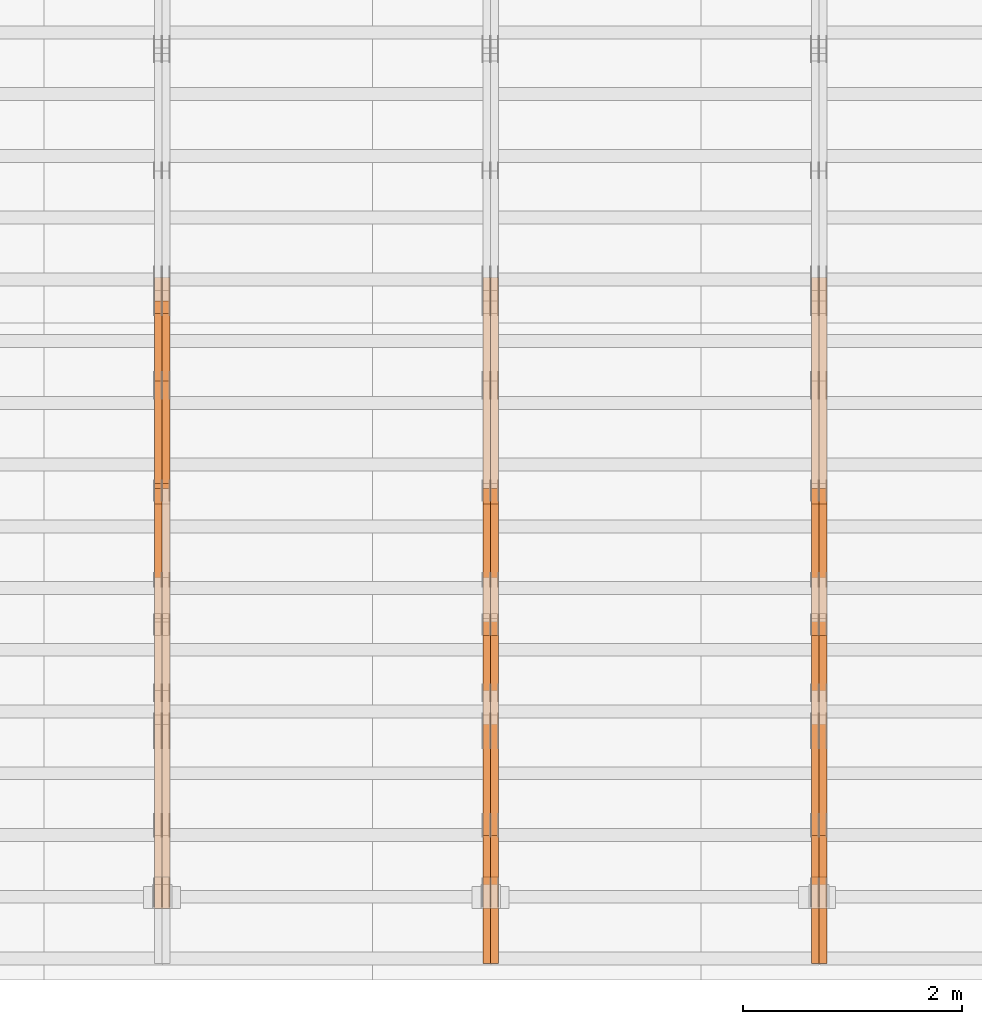
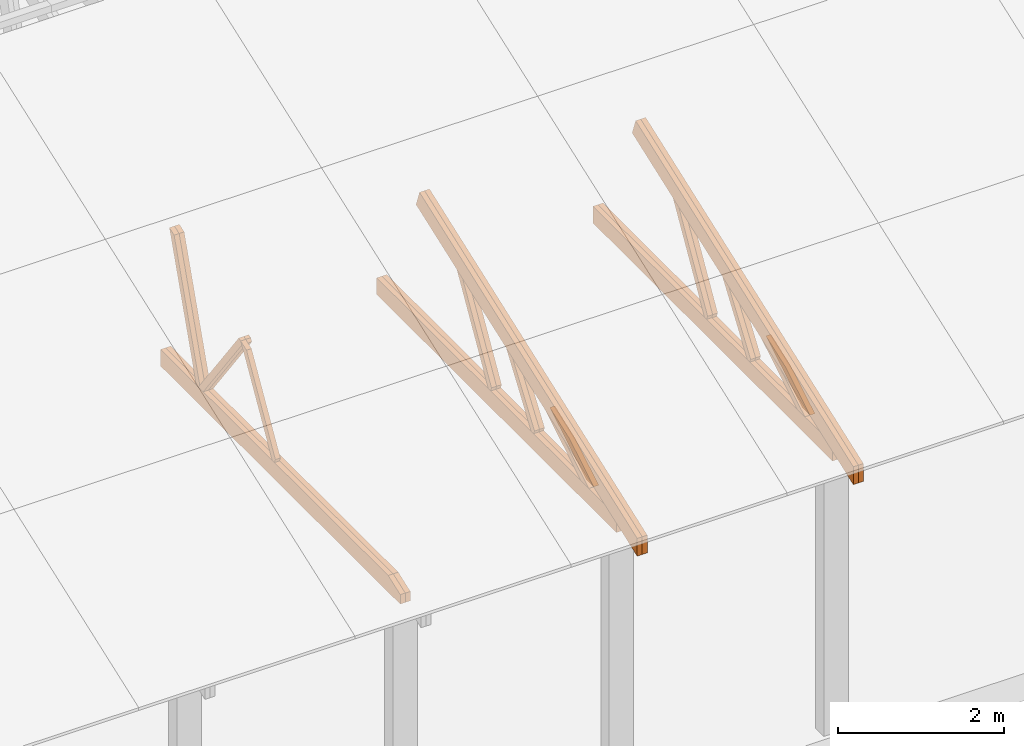
# One storey, part 23 of 189: 27 proxies.
"""IFC2X3 building model written with IfcOpenShell, lengths in millimetres."""

from ifc_helpers import new_model, entity, si_unit, converted_unit, derived_unit, direction, frame, origin, place, context, subcontext, project, spatial, polyline, outline, extrude, source, transform, mapped, material, type_object, type_shapes, element, save


model = new_model("IFC2X3")

# Units and contexts
model_context = context("Model", 3, precision=0.01, world=origin(), true_north=direction((6.12303176911189e-17, 1.0)))
body_context = subcontext(model_context, "Body", "Model", "MODEL_VIEW")
ifc_project = project(units=[si_unit("LENGTHUNIT", "METRE", prefix="MILLI"), si_unit("AREAUNIT", "SQUARE_METRE"), si_unit("VOLUMEUNIT", "CUBIC_METRE"), converted_unit("PLANEANGLEUNIT", "DEGREE", entity("IfcRatioMeasure", 0.0174532925199433), si_unit("PLANEANGLEUNIT", "RADIAN"), dimensions=[0, 0, 0, 0, 0, 0, 0]), si_unit("MASSUNIT", "GRAM", prefix="KILO"), derived_unit("MASSDENSITYUNIT", [(si_unit("MASSUNIT", "GRAM", prefix="KILO"), 1), (si_unit("LENGTHUNIT", "METRE"), -3)]), si_unit("TIMEUNIT", "SECOND"), si_unit("FREQUENCYUNIT", "HERTZ"), si_unit("THERMODYNAMICTEMPERATUREUNIT", "DEGREE_CELSIUS"), derived_unit("THERMALTRANSMITTANCEUNIT", [(si_unit("MASSUNIT", "GRAM", prefix="KILO"), 1), (si_unit("THERMODYNAMICTEMPERATUREUNIT", "KELVIN"), -1), (si_unit("TIMEUNIT", "SECOND"), -3)]), derived_unit("VOLUMETRICFLOWRATEUNIT", [(si_unit("LENGTHUNIT", "METRE"), 3), (si_unit("TIMEUNIT", "SECOND"), -1)]), si_unit("ELECTRICCURRENTUNIT", "AMPERE"), si_unit("ELECTRICVOLTAGEUNIT", "VOLT"), si_unit("POWERUNIT", "WATT"), si_unit("FORCEUNIT", "NEWTON"), si_unit("ILLUMINANCEUNIT", "LUX"), si_unit("LUMINOUSFLUXUNIT", "LUMEN"), si_unit("LUMINOUSINTENSITYUNIT", "CANDELA"), derived_unit("USERDEFINED", [(si_unit("MASSUNIT", "GRAM", prefix="KILO"), -1), (si_unit("LENGTHUNIT", "METRE"), -2), (si_unit("TIMEUNIT", "SECOND"), 3), (si_unit("LUMINOUSFLUXUNIT", "LUMEN"), 1)]), derived_unit("LINEARVELOCITYUNIT", [(si_unit("LENGTHUNIT", "METRE"), 1), (si_unit("TIMEUNIT", "SECOND"), -1)]), si_unit("PRESSUREUNIT", "PASCAL"), derived_unit("USERDEFINED", [(si_unit("LENGTHUNIT", "METRE"), -2), (si_unit("MASSUNIT", "GRAM", prefix="KILO"), 1), (si_unit("TIMEUNIT", "SECOND"), -2)])], contexts=[model_context])

# Site, building, storey
site_placement = place(None, origin())
site = spatial("IfcSite", under=ifc_project, at=site_placement, CompositionType="ELEMENT")
building_placement = place(site_placement, origin())
building = spatial("IfcBuilding", under=site, at=building_placement, CompositionType="ELEMENT")
storey_placement = place(building_placement, origin())
storey = spatial("IfcBuildingStorey", under=building, at=storey_placement, Name="Default", CompositionType="ELEMENT", Elevation=0.0)

# Proxies
ifc_material_1 = material(Name="IfcSurfaceStyle #160734")
building_element_proxy_type_1 = type_object("IfcBuildingElementProxyType", Name="T1-W11 160732", PredefinedType="NOTDEFINED", material=ifc_material_1)
shared_shape_1 = source(origin(), body_context, "Body", "SweptSolid", [
    extrude(outline(polyline([(593.358012843793, -552.565239103314), (742.388662259985, -552.565239103314), (-410.498749190676, 401.275038694583), (-462.246133468927, 382.44069706518), (-463.001792444175, 321.414742446865), (593.358012843793, -552.565239103314)])), frame((599.94412413079, 47.5003788877286, 0.0), z_axis=(0.0, 0.0, 1.0), x_axis=(0.770483455324544, 0.637459994879013, 0.0)), (0.0, 0.0, 1.0), 69.9999999999999),
])
type_shapes(building_element_proxy_type_1, [shared_shape_1])
proxy_1_placement = place(building_placement, frame((30300.0, 2983.26655629375, 269.034992751429), z_axis=(-1.0, 0.0, 0.0), x_axis=(0.0, 0.505995901100606, 0.862535882192379)))
element("IfcBuildingElementProxy", 1, at=proxy_1_placement, inside=storey, type_object=building_element_proxy_type_1, material=ifc_material_1, Name="T1-W11", context=body_context, shape_type="MappedRepresentation", body=[
    mapped(shared_shape_1, transform((0.0, 0.0, 0.0), scale=1.0)),
])
ifc_material_2 = material(Name="IfcSurfaceStyle #160668")
building_element_proxy_type_2 = type_object("IfcBuildingElementProxyType", Name="T1-W11 160666", PredefinedType="NOTDEFINED", material=ifc_material_2)
shared_shape_2 = source(origin(), body_context, "Body", "SweptSolid", [
    extrude(outline(polyline([(593.358012843793, -552.565239103314), (742.388662259985, -552.565239103314), (-410.498749190676, 401.275038694583), (-462.246133468927, 382.44069706518), (-463.001792444175, 321.414742446865), (593.358012843793, -552.565239103314)])), frame((599.94412413079, 47.5003788877286, 0.0), z_axis=(0.0, 0.0, 1.0), x_axis=(0.770483455324544, 0.637459994879013, 0.0)), (0.0, 0.0, 1.0), 69.9999999999999),
])
type_shapes(building_element_proxy_type_2, [shared_shape_2])
proxy_2_placement = place(building_placement, frame((30230.0, 2983.26655629375, 269.034992751429), z_axis=(-1.0, 0.0, 0.0), x_axis=(0.0, 0.505995901100606, 0.862535882192379)))
element("IfcBuildingElementProxy", 2, at=proxy_2_placement, inside=storey, type_object=building_element_proxy_type_2, material=ifc_material_2, Name="T1-W11", context=body_context, shape_type="MappedRepresentation", body=[
    mapped(shared_shape_2, transform((0.0, 0.0, 0.0), scale=1.0)),
])
ifc_material_3 = material(Name="IfcSurfaceStyle #160206")
building_element_proxy_type_3 = type_object("IfcBuildingElementProxyType", Name="T1-W13 160204", PredefinedType="NOTDEFINED", material=ifc_material_3)
shared_shape_3 = source(origin(), body_context, "Body", "SweptSolid", [
    extrude(outline(polyline([(404.740440720218, -341.48092914206), (570.336320797765, -341.48092914206), (-287.911826743206, 259.650691447848), (-342.395697357435, 239.820346030744), (-344.769237417342, 183.490820805529), (404.740440720218, -341.48092914206)])), frame((418.029573061951, 47.5005675782689, 0.0), z_axis=(0.0, 0.0, 1.0), x_axis=(0.819070847746389, 0.573692379565924, 0.0)), (0.0, 0.0, 1.0), 69.9999999999999),
])
type_shapes(building_element_proxy_type_3, [shared_shape_3])
proxy_3_placement = place(building_placement, frame((30300.0, 1951.16403402681, 272.239720286334), z_axis=(-1.0, 0.0, 0.0), x_axis=(0.0, 0.573462629043499, 0.819231721242848)))
element("IfcBuildingElementProxy", 3, at=proxy_3_placement, inside=storey, type_object=building_element_proxy_type_3, material=ifc_material_3, Name="T1-W13", context=body_context, shape_type="MappedRepresentation", body=[
    mapped(shared_shape_3, transform((0.0, 0.0, 0.0), scale=1.0)),
])
ifc_material_4 = material(Name="IfcSurfaceStyle #160140")
building_element_proxy_type_4 = type_object("IfcBuildingElementProxyType", Name="T1-W13 160138", PredefinedType="NOTDEFINED", material=ifc_material_4)
shared_shape_4 = source(origin(), body_context, "Body", "SweptSolid", [
    extrude(outline(polyline([(404.740440720218, -341.48092914206), (570.336320797765, -341.48092914206), (-287.911826743206, 259.650691447848), (-342.395697357435, 239.820346030744), (-344.769237417342, 183.490820805529), (404.740440720218, -341.48092914206)])), frame((418.029573061951, 47.5005675782689, 0.0), z_axis=(0.0, 0.0, 1.0), x_axis=(0.819070847746389, 0.573692379565924, 0.0)), (0.0, 0.0, 1.0), 69.9999999999999),
])
type_shapes(building_element_proxy_type_4, [shared_shape_4])
proxy_4_placement = place(building_placement, frame((30230.0, 1951.16403402681, 272.239720286334), z_axis=(-1.0, 0.0, 0.0), x_axis=(0.0, 0.573462629043499, 0.819231721242848)))
element("IfcBuildingElementProxy", 4, at=proxy_4_placement, inside=storey, type_object=building_element_proxy_type_4, material=ifc_material_4, Name="T1-W13", context=body_context, shape_type="MappedRepresentation", body=[
    mapped(shared_shape_4, transform((0.0, 0.0, 0.0), scale=1.0)),
])
ifc_material_5 = material(Name="IfcSurfaceStyle #159678")
building_element_proxy_type_5 = type_object("IfcBuildingElementProxyType", Name="T1-W12 159676", PredefinedType="NOTDEFINED", material=ifc_material_5)
shared_shape_5 = source(origin(), body_context, "Body", "SweptSolid", [
    extrude(outline(polyline([(-671.888430889784, -47.499785620702), (344.892972119224, -47.499785620702), (503.856463083211, 47.4997856207019), (-176.861004312651, 47.499785620702), (-671.888430889784, -47.499785620702)])), frame((503.857114243549, 47.5002636410509, 0.0), z_axis=(0.0, 0.0, 1.0), x_axis=(-1.0, 0.0, 0.0)), (0.0, 0.0, 1.0), 69.9999999999999),
])
type_shapes(building_element_proxy_type_5, [shared_shape_5])
proxy_5_placement = place(building_placement, frame((30300.0, 665.58122707747, 245.000076287477), z_axis=(-1.0, 0.0, 0.0), x_axis=(0.0, 0.858392121304013, 0.51299411895576)))
element("IfcBuildingElementProxy", 5, at=proxy_5_placement, inside=storey, type_object=building_element_proxy_type_5, material=ifc_material_5, Name="T1-W12", context=body_context, shape_type="MappedRepresentation", body=[
    mapped(shared_shape_5, transform((0.0, 0.0, 0.0), scale=1.0)),
])
ifc_material_6 = material(Name="IfcSurfaceStyle #159621")
building_element_proxy_type_6 = type_object("IfcBuildingElementProxyType", Name="T1-W12 159619", PredefinedType="NOTDEFINED", material=ifc_material_6)
shared_shape_6 = source(origin(), body_context, "Body", "SweptSolid", [
    extrude(outline(polyline([(-671.888430889784, -47.499785620702), (344.892972119224, -47.499785620702), (503.856463083211, 47.4997856207019), (-176.861004312651, 47.499785620702), (-671.888430889784, -47.499785620702)])), frame((503.857114243549, 47.5002636410509, 0.0), z_axis=(0.0, 0.0, 1.0), x_axis=(-1.0, 0.0, 0.0)), (0.0, 0.0, 1.0), 69.9999999999999),
])
type_shapes(building_element_proxy_type_6, [shared_shape_6])
proxy_6_placement = place(building_placement, frame((30230.0, 665.58122707747, 245.000076287477), z_axis=(-1.0, 0.0, 0.0), x_axis=(0.0, 0.858392121304013, 0.51299411895576)))
element("IfcBuildingElementProxy", 6, at=proxy_6_placement, inside=storey, type_object=building_element_proxy_type_6, material=ifc_material_6, Name="T1-W12", context=body_context, shape_type="MappedRepresentation", body=[
    mapped(shared_shape_6, transform((0.0, 0.0, 0.0), scale=1.0)),
])
ifc_material_7 = material(Name="IfcSurfaceStyle #158862")
building_element_proxy_type_7 = type_object("IfcBuildingElementProxyType", Name="T1-B2 158860", PredefinedType="NOTDEFINED", material=ifc_material_7)
shared_shape_7 = source(origin(), body_context, "Body", "SweptSolid", [
    extrude(outline(polyline([(-3399.385546875, -125.855288696291), (2363.08125, -125.855288696291), (2363.08125, 13.4211547851572), (2072.60859375, 119.144711303712), (-3399.385546875, 119.144711303712), (-3399.385546875, -125.855288696291)])), frame((2363.08125, 119.144711303712, 0.0), z_axis=(0.0, 0.0, 1.0), x_axis=(-1.0, 0.0, 0.0)), (0.0, 0.0, 1.0), 69.9999999999997),
])
type_shapes(building_element_proxy_type_7, [shared_shape_7])
proxy_7_placement = place(building_placement, frame((30300.0, 0.0, 245.0), z_axis=(-1.0, 0.0, 0.0), x_axis=(0.0, 1.0, 0.0)))
element("IfcBuildingElementProxy", 7, at=proxy_7_placement, inside=storey, type_object=building_element_proxy_type_7, material=ifc_material_7, Name="T1-B2", context=body_context, shape_type="MappedRepresentation", body=[
    mapped(shared_shape_7, transform((0.0, 0.0, 0.0), scale=1.0)),
])
ifc_material_8 = material(Name="IfcSurfaceStyle #158796")
building_element_proxy_type_8 = type_object("IfcBuildingElementProxyType", Name="T1-B2 158794", PredefinedType="NOTDEFINED", material=ifc_material_8)
shared_shape_8 = source(origin(), body_context, "Body", "SweptSolid", [
    extrude(outline(polyline([(-3399.385546875, -125.855288696291), (2363.08125, -125.855288696291), (2363.08125, 13.4211547851572), (2072.60859375, 119.144711303712), (-3399.385546875, 119.144711303712), (-3399.385546875, -125.855288696291)])), frame((2363.08125, 119.144711303712, 0.0), z_axis=(0.0, 0.0, 1.0), x_axis=(-1.0, 0.0, 0.0)), (0.0, 0.0, 1.0), 69.9999999999997),
])
type_shapes(building_element_proxy_type_8, [shared_shape_8])
proxy_8_placement = place(building_placement, frame((30230.0, 0.0, 245.0), z_axis=(-1.0, 0.0, 0.0), x_axis=(0.0, 1.0, 0.0)))
element("IfcBuildingElementProxy", 8, at=proxy_8_placement, inside=storey, type_object=building_element_proxy_type_8, material=ifc_material_8, Name="T1-B2", context=body_context, shape_type="MappedRepresentation", body=[
    mapped(shared_shape_8, transform((0.0, 0.0, 0.0), scale=1.0)),
])
ifc_material_9 = material(Name="IfcSurfaceStyle #158730")
building_element_proxy_type_9 = type_object("IfcBuildingElementProxyType", Name="T1-T2 158728", PredefinedType="NOTDEFINED", material=ifc_material_9)
shared_shape_9 = source(origin(), body_context, "Body", "SweptSolid", [
    extrude(outline(polyline([(-2763.12044548193, -122.499971764318), (2807.70681121203, -122.499971764318), (2807.70678531127, 122.499971764318), (-2852.29315104137, 122.499971764318), (-2763.12044548193, -122.499971764318)])), frame((2807.70684902043, 122.500023191939, 0.0), z_axis=(0.0, 0.0, 1.0), x_axis=(-1.0, 0.0, 0.0)), (0.0, 0.0, 1.0), 69.9999999999997),
])
type_shapes(building_element_proxy_type_9, [shared_shape_9])
proxy_9_placement = place(building_placement, frame((30300.0, 4818.66023370631, 1893.1253396746), z_axis=(-1.0, 0.0, 0.0), x_axis=(0.0, -0.939692620785908, -0.342020143325669)))
element("IfcBuildingElementProxy", 9, at=proxy_9_placement, inside=storey, type_object=building_element_proxy_type_9, material=ifc_material_9, Name="T1-T2", context=body_context, shape_type="MappedRepresentation", body=[
    mapped(shared_shape_9, transform((0.0, 0.0, 0.0), scale=1.0)),
])
ifc_material_10 = material(Name="IfcSurfaceStyle #158673")
building_element_proxy_type_10 = type_object("IfcBuildingElementProxyType", Name="T1-T2 158671", PredefinedType="NOTDEFINED", material=ifc_material_10)
shared_shape_10 = source(origin(), body_context, "Body", "SweptSolid", [
    extrude(outline(polyline([(-2763.12044548193, -122.499971764318), (2807.70681121203, -122.499971764318), (2807.70678531127, 122.499971764318), (-2852.29315104137, 122.499971764318), (-2763.12044548193, -122.499971764318)])), frame((2807.70684902043, 122.500023191939, 0.0), z_axis=(0.0, 0.0, 1.0), x_axis=(-1.0, 0.0, 0.0)), (0.0, 0.0, 1.0), 69.9999999999997),
])
type_shapes(building_element_proxy_type_10, [shared_shape_10])
proxy_10_placement = place(building_placement, frame((30230.0, 4818.66023370631, 1893.1253396746), z_axis=(-1.0, 0.0, 0.0), x_axis=(0.0, -0.939692620785908, -0.342020143325669)))
element("IfcBuildingElementProxy", 10, at=proxy_10_placement, inside=storey, type_object=building_element_proxy_type_10, material=ifc_material_10, Name="T1-T2", context=body_context, shape_type="MappedRepresentation", body=[
    mapped(shared_shape_10, transform((0.0, 0.0, 0.0), scale=1.0)),
])
ifc_material_11 = material(Name="IfcSurfaceStyle #144944")
building_element_proxy_type_11 = type_object("IfcBuildingElementProxyType", Name="T1-W11 144942", PredefinedType="NOTDEFINED", material=ifc_material_11)
shared_shape_11 = source(origin(), body_context, "Body", "SweptSolid", [
    extrude(outline(polyline([(593.358012843793, -552.565239103314), (742.388662259985, -552.565239103314), (-410.498749190676, 401.275038694583), (-462.246133468927, 382.44069706518), (-463.001792444175, 321.414742446865), (593.358012843793, -552.565239103314)])), frame((599.94412413079, 47.5003788877286, 0.0), z_axis=(0.0, 0.0, 1.0), x_axis=(0.770483455324544, 0.637459994879013, 0.0)), (0.0, 0.0, 1.0), 69.9999999999999),
])
type_shapes(building_element_proxy_type_11, [shared_shape_11])
proxy_11_placement = place(building_placement, frame((27300.0, 2983.26655629375, 269.034992751429), z_axis=(-1.0, 0.0, 0.0), x_axis=(0.0, 0.505995901100606, 0.862535882192379)))
element("IfcBuildingElementProxy", 11, at=proxy_11_placement, inside=storey, type_object=building_element_proxy_type_11, material=ifc_material_11, Name="T1-W11", context=body_context, shape_type="MappedRepresentation", body=[
    mapped(shared_shape_11, transform((0.0, 0.0, 0.0), scale=1.0)),
])
ifc_material_12 = material(Name="IfcSurfaceStyle #144878")
building_element_proxy_type_12 = type_object("IfcBuildingElementProxyType", Name="T1-W11 144876", PredefinedType="NOTDEFINED", material=ifc_material_12)
shared_shape_12 = source(origin(), body_context, "Body", "SweptSolid", [
    extrude(outline(polyline([(593.358012843793, -552.565239103314), (742.388662259985, -552.565239103314), (-410.498749190676, 401.275038694583), (-462.246133468927, 382.44069706518), (-463.001792444175, 321.414742446865), (593.358012843793, -552.565239103314)])), frame((599.94412413079, 47.5003788877286, 0.0), z_axis=(0.0, 0.0, 1.0), x_axis=(0.770483455324544, 0.637459994879013, 0.0)), (0.0, 0.0, 1.0), 69.9999999999999),
])
type_shapes(building_element_proxy_type_12, [shared_shape_12])
proxy_12_placement = place(building_placement, frame((27230.0, 2983.26655629375, 269.034992751429), z_axis=(-1.0, 0.0, 0.0), x_axis=(0.0, 0.505995901100606, 0.862535882192379)))
element("IfcBuildingElementProxy", 12, at=proxy_12_placement, inside=storey, type_object=building_element_proxy_type_12, material=ifc_material_12, Name="T1-W11", context=body_context, shape_type="MappedRepresentation", body=[
    mapped(shared_shape_12, transform((0.0, 0.0, 0.0), scale=1.0)),
])
ifc_material_13 = material(Name="IfcSurfaceStyle #144416")
building_element_proxy_type_13 = type_object("IfcBuildingElementProxyType", Name="T1-W13 144414", PredefinedType="NOTDEFINED", material=ifc_material_13)
shared_shape_13 = source(origin(), body_context, "Body", "SweptSolid", [
    extrude(outline(polyline([(404.740440720218, -341.48092914206), (570.336320797765, -341.48092914206), (-287.911826743206, 259.650691447848), (-342.395697357435, 239.820346030744), (-344.769237417342, 183.490820805529), (404.740440720218, -341.48092914206)])), frame((418.029573061951, 47.5005675782689, 0.0), z_axis=(0.0, 0.0, 1.0), x_axis=(0.819070847746389, 0.573692379565924, 0.0)), (0.0, 0.0, 1.0), 69.9999999999999),
])
type_shapes(building_element_proxy_type_13, [shared_shape_13])
proxy_13_placement = place(building_placement, frame((27300.0, 1951.16403402681, 272.239720286334), z_axis=(-1.0, 0.0, 0.0), x_axis=(0.0, 0.573462629043499, 0.819231721242848)))
element("IfcBuildingElementProxy", 13, at=proxy_13_placement, inside=storey, type_object=building_element_proxy_type_13, material=ifc_material_13, Name="T1-W13", context=body_context, shape_type="MappedRepresentation", body=[
    mapped(shared_shape_13, transform((0.0, 0.0, 0.0), scale=1.0)),
])
ifc_material_14 = material(Name="IfcSurfaceStyle #144350")
building_element_proxy_type_14 = type_object("IfcBuildingElementProxyType", Name="T1-W13 144348", PredefinedType="NOTDEFINED", material=ifc_material_14)
shared_shape_14 = source(origin(), body_context, "Body", "SweptSolid", [
    extrude(outline(polyline([(404.740440720218, -341.48092914206), (570.336320797765, -341.48092914206), (-287.911826743206, 259.650691447848), (-342.395697357435, 239.820346030744), (-344.769237417342, 183.490820805529), (404.740440720218, -341.48092914206)])), frame((418.029573061951, 47.5005675782689, 0.0), z_axis=(0.0, 0.0, 1.0), x_axis=(0.819070847746389, 0.573692379565924, 0.0)), (0.0, 0.0, 1.0), 69.9999999999999),
])
type_shapes(building_element_proxy_type_14, [shared_shape_14])
proxy_14_placement = place(building_placement, frame((27230.0, 1951.16403402681, 272.239720286334), z_axis=(-1.0, 0.0, 0.0), x_axis=(0.0, 0.573462629043499, 0.819231721242848)))
element("IfcBuildingElementProxy", 14, at=proxy_14_placement, inside=storey, type_object=building_element_proxy_type_14, material=ifc_material_14, Name="T1-W13", context=body_context, shape_type="MappedRepresentation", body=[
    mapped(shared_shape_14, transform((0.0, 0.0, 0.0), scale=1.0)),
])
ifc_material_15 = material(Name="IfcSurfaceStyle #143888")
building_element_proxy_type_15 = type_object("IfcBuildingElementProxyType", Name="T1-W12 143886", PredefinedType="NOTDEFINED", material=ifc_material_15)
shared_shape_15 = source(origin(), body_context, "Body", "SweptSolid", [
    extrude(outline(polyline([(-671.888430889784, -47.499785620702), (344.892972119224, -47.499785620702), (503.856463083211, 47.4997856207019), (-176.861004312651, 47.499785620702), (-671.888430889784, -47.499785620702)])), frame((503.857114243549, 47.5002636410509, 0.0), z_axis=(0.0, 0.0, 1.0), x_axis=(-1.0, 0.0, 0.0)), (0.0, 0.0, 1.0), 69.9999999999999),
])
type_shapes(building_element_proxy_type_15, [shared_shape_15])
proxy_15_placement = place(building_placement, frame((27300.0, 665.58122707747, 245.000076287477), z_axis=(-1.0, 0.0, 0.0), x_axis=(0.0, 0.858392121304013, 0.51299411895576)))
element("IfcBuildingElementProxy", 15, at=proxy_15_placement, inside=storey, type_object=building_element_proxy_type_15, material=ifc_material_15, Name="T1-W12", context=body_context, shape_type="MappedRepresentation", body=[
    mapped(shared_shape_15, transform((0.0, 0.0, 0.0), scale=1.0)),
])
ifc_material_16 = material(Name="IfcSurfaceStyle #143831")
building_element_proxy_type_16 = type_object("IfcBuildingElementProxyType", Name="T1-W12 143829", PredefinedType="NOTDEFINED", material=ifc_material_16)
shared_shape_16 = source(origin(), body_context, "Body", "SweptSolid", [
    extrude(outline(polyline([(-671.888430889784, -47.499785620702), (344.892972119224, -47.499785620702), (503.856463083211, 47.4997856207019), (-176.861004312651, 47.499785620702), (-671.888430889784, -47.499785620702)])), frame((503.857114243549, 47.5002636410509, 0.0), z_axis=(0.0, 0.0, 1.0), x_axis=(-1.0, 0.0, 0.0)), (0.0, 0.0, 1.0), 69.9999999999999),
])
type_shapes(building_element_proxy_type_16, [shared_shape_16])
proxy_16_placement = place(building_placement, frame((27230.0, 665.58122707747, 245.000076287477), z_axis=(-1.0, 0.0, 0.0), x_axis=(0.0, 0.858392121304013, 0.51299411895576)))
element("IfcBuildingElementProxy", 16, at=proxy_16_placement, inside=storey, type_object=building_element_proxy_type_16, material=ifc_material_16, Name="T1-W12", context=body_context, shape_type="MappedRepresentation", body=[
    mapped(shared_shape_16, transform((0.0, 0.0, 0.0), scale=1.0)),
])
ifc_material_17 = material(Name="IfcSurfaceStyle #143072")
building_element_proxy_type_17 = type_object("IfcBuildingElementProxyType", Name="T1-B2 143070", PredefinedType="NOTDEFINED", material=ifc_material_17)
shared_shape_17 = source(origin(), body_context, "Body", "SweptSolid", [
    extrude(outline(polyline([(-3399.385546875, -125.855288696291), (2363.08125, -125.855288696291), (2363.08125, 13.4211547851572), (2072.60859375, 119.144711303712), (-3399.385546875, 119.144711303712), (-3399.385546875, -125.855288696291)])), frame((2363.08125, 119.144711303712, 0.0), z_axis=(0.0, 0.0, 1.0), x_axis=(-1.0, 0.0, 0.0)), (0.0, 0.0, 1.0), 69.9999999999997),
])
type_shapes(building_element_proxy_type_17, [shared_shape_17])
proxy_17_placement = place(building_placement, frame((27300.0, 0.0, 245.0), z_axis=(-1.0, 0.0, 0.0), x_axis=(0.0, 1.0, 0.0)))
element("IfcBuildingElementProxy", 17, at=proxy_17_placement, inside=storey, type_object=building_element_proxy_type_17, material=ifc_material_17, Name="T1-B2", context=body_context, shape_type="MappedRepresentation", body=[
    mapped(shared_shape_17, transform((0.0, 0.0, 0.0), scale=1.0)),
])
ifc_material_18 = material(Name="IfcSurfaceStyle #143006")
building_element_proxy_type_18 = type_object("IfcBuildingElementProxyType", Name="T1-B2 143004", PredefinedType="NOTDEFINED", material=ifc_material_18)
shared_shape_18 = source(origin(), body_context, "Body", "SweptSolid", [
    extrude(outline(polyline([(-3399.385546875, -125.855288696291), (2363.08125, -125.855288696291), (2363.08125, 13.4211547851572), (2072.60859375, 119.144711303712), (-3399.385546875, 119.144711303712), (-3399.385546875, -125.855288696291)])), frame((2363.08125, 119.144711303712, 0.0), z_axis=(0.0, 0.0, 1.0), x_axis=(-1.0, 0.0, 0.0)), (0.0, 0.0, 1.0), 69.9999999999997),
])
type_shapes(building_element_proxy_type_18, [shared_shape_18])
proxy_18_placement = place(building_placement, frame((27230.0, 0.0, 245.0), z_axis=(-1.0, 0.0, 0.0), x_axis=(0.0, 1.0, 0.0)))
element("IfcBuildingElementProxy", 18, at=proxy_18_placement, inside=storey, type_object=building_element_proxy_type_18, material=ifc_material_18, Name="T1-B2", context=body_context, shape_type="MappedRepresentation", body=[
    mapped(shared_shape_18, transform((0.0, 0.0, 0.0), scale=1.0)),
])
ifc_material_19 = material(Name="IfcSurfaceStyle #142940")
building_element_proxy_type_19 = type_object("IfcBuildingElementProxyType", Name="T1-T2 142938", PredefinedType="NOTDEFINED", material=ifc_material_19)
shared_shape_19 = source(origin(), body_context, "Body", "SweptSolid", [
    extrude(outline(polyline([(-2763.12044548193, -122.499971764318), (2807.70681121203, -122.499971764318), (2807.70678531127, 122.499971764318), (-2852.29315104137, 122.499971764318), (-2763.12044548193, -122.499971764318)])), frame((2807.70684902043, 122.500023191939, 0.0), z_axis=(0.0, 0.0, 1.0), x_axis=(-1.0, 0.0, 0.0)), (0.0, 0.0, 1.0), 69.9999999999997),
])
type_shapes(building_element_proxy_type_19, [shared_shape_19])
proxy_19_placement = place(building_placement, frame((27300.0, 4818.66023370631, 1893.1253396746), z_axis=(-1.0, 0.0, 0.0), x_axis=(0.0, -0.939692620785908, -0.342020143325669)))
element("IfcBuildingElementProxy", 19, at=proxy_19_placement, inside=storey, type_object=building_element_proxy_type_19, material=ifc_material_19, Name="T1-T2", context=body_context, shape_type="MappedRepresentation", body=[
    mapped(shared_shape_19, transform((0.0, 0.0, 0.0), scale=1.0)),
])
ifc_material_20 = material(Name="IfcSurfaceStyle #142883")
building_element_proxy_type_20 = type_object("IfcBuildingElementProxyType", Name="T1-T2 142881", PredefinedType="NOTDEFINED", material=ifc_material_20)
shared_shape_20 = source(origin(), body_context, "Body", "SweptSolid", [
    extrude(outline(polyline([(-2763.12044548193, -122.499971764318), (2807.70681121203, -122.499971764318), (2807.70678531127, 122.499971764318), (-2852.29315104137, 122.499971764318), (-2763.12044548193, -122.499971764318)])), frame((2807.70684902043, 122.500023191939, 0.0), z_axis=(0.0, 0.0, 1.0), x_axis=(-1.0, 0.0, 0.0)), (0.0, 0.0, 1.0), 69.9999999999997),
])
type_shapes(building_element_proxy_type_20, [shared_shape_20])
proxy_20_placement = place(building_placement, frame((27230.0, 4818.66023370631, 1893.1253396746), z_axis=(-1.0, 0.0, 0.0), x_axis=(0.0, -0.939692620785908, -0.342020143325669)))
element("IfcBuildingElementProxy", 20, at=proxy_20_placement, inside=storey, type_object=building_element_proxy_type_20, material=ifc_material_20, Name="T1-T2", context=body_context, shape_type="MappedRepresentation", body=[
    mapped(shared_shape_20, transform((0.0, 0.0, 0.0), scale=1.0)),
])
ifc_material_21 = material(Name="IfcSurfaceStyle #129682")
building_element_proxy_type_21 = type_object("IfcBuildingElementProxyType", Name="T1-W9 129680", PredefinedType="NOTDEFINED", material=ifc_material_21)
shared_shape_21 = source(origin(), body_context, "Body", "SweptSolid", [
    extrude(outline(polyline([(-1227.3969292634, -47.5000382896404), (793.242467803064, -47.5000382896404), (809.267705296822, 1.0956605530188e-05), (776.329919980315, 47.5000328113376), (-1151.4431638168, 47.5000328113376), (-1227.3969292634, -47.5000382896404)])), frame((809.267705296822, 47.5000328113376, 0.0), z_axis=(0.0, 0.0, 1.0), x_axis=(-1.0, 0.0, 0.0)), (0.0, 0.0, 1.0), 69.9999999999999),
])
type_shapes(building_element_proxy_type_21, [shared_shape_21])
proxy_21_placement = place(building_placement, frame((24300.0, 4809.76380889125, 260.184242613649), z_axis=(-1.0, 0.0, 0.0), x_axis=(0.0, 0.31966811847134, 0.947529574226047)))
element("IfcBuildingElementProxy", 21, at=proxy_21_placement, inside=storey, type_object=building_element_proxy_type_21, material=ifc_material_21, Name="T1-W9", context=body_context, shape_type="MappedRepresentation", body=[
    mapped(shared_shape_21, transform((0.0, 0.0, 0.0), scale=1.0)),
])
ifc_material_22 = material(Name="IfcSurfaceStyle #129616")
building_element_proxy_type_22 = type_object("IfcBuildingElementProxyType", Name="T1-W9 129614", PredefinedType="NOTDEFINED", material=ifc_material_22)
shared_shape_22 = source(origin(), body_context, "Body", "SweptSolid", [
    extrude(outline(polyline([(-1227.3969292634, -47.5000382896404), (793.242467803064, -47.5000382896404), (809.267705296822, 1.0956605530188e-05), (776.329919980315, 47.5000328113376), (-1151.4431638168, 47.5000328113376), (-1227.3969292634, -47.5000382896404)])), frame((809.267705296822, 47.5000328113376, 0.0), z_axis=(0.0, 0.0, 1.0), x_axis=(-1.0, 0.0, 0.0)), (0.0, 0.0, 1.0), 69.9999999999999),
])
type_shapes(building_element_proxy_type_22, [shared_shape_22])
proxy_22_placement = place(building_placement, frame((24230.0, 4809.76380889125, 260.184242613649), z_axis=(-1.0, 0.0, 0.0), x_axis=(0.0, 0.31966811847134, 0.947529574226047)))
element("IfcBuildingElementProxy", 22, at=proxy_22_placement, inside=storey, type_object=building_element_proxy_type_22, material=ifc_material_22, Name="T1-W9", context=body_context, shape_type="MappedRepresentation", body=[
    mapped(shared_shape_22, transform((0.0, 0.0, 0.0), scale=1.0)),
])
ifc_material_23 = material(Name="IfcSurfaceStyle #129418")
building_element_proxy_type_23 = type_object("IfcBuildingElementProxyType", Name="T1-W10 129416", PredefinedType="NOTDEFINED", material=ifc_material_23)
shared_shape_23 = source(origin(), body_context, "Body", "SweptSolid", [
    extrude(outline(polyline([(-922.639472665691, -47.5001890573134), (629.920966338637, -47.5001890573134), (650.067737483374, 0.000694680531158376), (635.89112756682, 47.4998417170478), (-993.240358723139, 47.4998417170478), (-922.639472665691, -47.5001890573134)])), frame((650.068202545693, 47.4999816623145, 0.0), z_axis=(0.0, 0.0, 1.0), x_axis=(-1.0, 0.0, 0.0)), (0.0, 0.0, 1.0), 69.9999999999999),
])
type_shapes(building_element_proxy_type_23, [shared_shape_23])
proxy_23_placement = place(building_placement, frame((24300.0, 3874.56126239818, 1563.95828147518), z_axis=(-1.0, 0.0, 0.0), x_axis=(0.0, 0.596486092002, -0.802623412347398)))
element("IfcBuildingElementProxy", 23, at=proxy_23_placement, inside=storey, type_object=building_element_proxy_type_23, material=ifc_material_23, Name="T1-W10", context=body_context, shape_type="MappedRepresentation", body=[
    mapped(shared_shape_23, transform((0.0, 0.0, 0.0), scale=1.0)),
])
ifc_material_24 = material(Name="IfcSurfaceStyle #129352")
building_element_proxy_type_24 = type_object("IfcBuildingElementProxyType", Name="T1-W10 129350", PredefinedType="NOTDEFINED", material=ifc_material_24)
shared_shape_24 = source(origin(), body_context, "Body", "SweptSolid", [
    extrude(outline(polyline([(-922.639472665691, -47.5001890573134), (629.920966338637, -47.5001890573134), (650.067737483374, 0.000694680531158376), (635.89112756682, 47.4998417170478), (-993.240358723139, 47.4998417170478), (-922.639472665691, -47.5001890573134)])), frame((650.068202545693, 47.4999816623145, 0.0), z_axis=(0.0, 0.0, 1.0), x_axis=(-1.0, 0.0, 0.0)), (0.0, 0.0, 1.0), 69.9999999999999),
])
type_shapes(building_element_proxy_type_24, [shared_shape_24])
proxy_24_placement = place(building_placement, frame((24230.0, 3874.56126239818, 1563.95828147518), z_axis=(-1.0, 0.0, 0.0), x_axis=(0.0, 0.596486092002, -0.802623412347398)))
element("IfcBuildingElementProxy", 24, at=proxy_24_placement, inside=storey, type_object=building_element_proxy_type_24, material=ifc_material_24, Name="T1-W10", context=body_context, shape_type="MappedRepresentation", body=[
    mapped(shared_shape_24, transform((0.0, 0.0, 0.0), scale=1.0)),
])
ifc_material_25 = material(Name="IfcSurfaceStyle #129088")
building_element_proxy_type_25 = type_object("IfcBuildingElementProxyType", Name="T1-W11 129086", PredefinedType="NOTDEFINED", material=ifc_material_25)
shared_shape_25 = source(origin(), body_context, "Body", "SweptSolid", [
    extrude(outline(polyline([(593.358012843793, -552.565239103314), (742.388662259985, -552.565239103314), (-410.498749190676, 401.275038694583), (-462.246133468927, 382.44069706518), (-463.001792444175, 321.414742446865), (593.358012843793, -552.565239103314)])), frame((599.94412413079, 47.5003788877286, 0.0), z_axis=(0.0, 0.0, 1.0), x_axis=(0.770483455324544, 0.637459994879013, 0.0)), (0.0, 0.0, 1.0), 69.9999999999999),
])
type_shapes(building_element_proxy_type_25, [shared_shape_25])
proxy_25_placement = place(building_placement, frame((24230.0, 2983.26655629375, 269.034992751429), z_axis=(-1.0, 0.0, 0.0), x_axis=(0.0, 0.505995901100606, 0.862535882192379)))
element("IfcBuildingElementProxy", 25, at=proxy_25_placement, inside=storey, type_object=building_element_proxy_type_25, material=ifc_material_25, Name="T1-W11", context=body_context, shape_type="MappedRepresentation", body=[
    mapped(shared_shape_25, transform((0.0, 0.0, 0.0), scale=1.0)),
])
ifc_material_26 = material(Name="IfcSurfaceStyle #127282")
building_element_proxy_type_26 = type_object("IfcBuildingElementProxyType", Name="T1-B2 127280", PredefinedType="NOTDEFINED", material=ifc_material_26)
shared_shape_26 = source(origin(), body_context, "Body", "SweptSolid", [
    extrude(outline(polyline([(-3399.385546875, -125.855288696291), (2363.08125, -125.855288696291), (2363.08125, 13.4211547851572), (2072.60859375, 119.144711303712), (-3399.385546875, 119.144711303712), (-3399.385546875, -125.855288696291)])), frame((2363.08125, 119.144711303712, 0.0), z_axis=(0.0, 0.0, 1.0), x_axis=(-1.0, 0.0, 0.0)), (0.0, 0.0, 1.0), 69.9999999999997),
])
type_shapes(building_element_proxy_type_26, [shared_shape_26])
proxy_26_placement = place(building_placement, frame((24300.0, 0.0, 245.0), z_axis=(-1.0, 0.0, 0.0), x_axis=(0.0, 1.0, 0.0)))
element("IfcBuildingElementProxy", 26, at=proxy_26_placement, inside=storey, type_object=building_element_proxy_type_26, material=ifc_material_26, Name="T1-B2", context=body_context, shape_type="MappedRepresentation", body=[
    mapped(shared_shape_26, transform((0.0, 0.0, 0.0), scale=1.0)),
])
ifc_material_27 = material(Name="IfcSurfaceStyle #127216")
building_element_proxy_type_27 = type_object("IfcBuildingElementProxyType", Name="T1-B2 127214", PredefinedType="NOTDEFINED", material=ifc_material_27)
shared_shape_27 = source(origin(), body_context, "Body", "SweptSolid", [
    extrude(outline(polyline([(-3399.385546875, -125.855288696291), (2363.08125, -125.855288696291), (2363.08125, 13.4211547851572), (2072.60859375, 119.144711303712), (-3399.385546875, 119.144711303712), (-3399.385546875, -125.855288696291)])), frame((2363.08125, 119.144711303712, 0.0), z_axis=(0.0, 0.0, 1.0), x_axis=(-1.0, 0.0, 0.0)), (0.0, 0.0, 1.0), 69.9999999999997),
])
type_shapes(building_element_proxy_type_27, [shared_shape_27])
proxy_27_placement = place(building_placement, frame((24230.0, 0.0, 245.0), z_axis=(-1.0, 0.0, 0.0), x_axis=(0.0, 1.0, 0.0)))
element("IfcBuildingElementProxy", 27, at=proxy_27_placement, inside=storey, type_object=building_element_proxy_type_27, material=ifc_material_27, Name="T1-B2", context=body_context, shape_type="MappedRepresentation", body=[
    mapped(shared_shape_27, transform((0.0, 0.0, 0.0), scale=1.0)),
])

save(model, "model.ifc")
